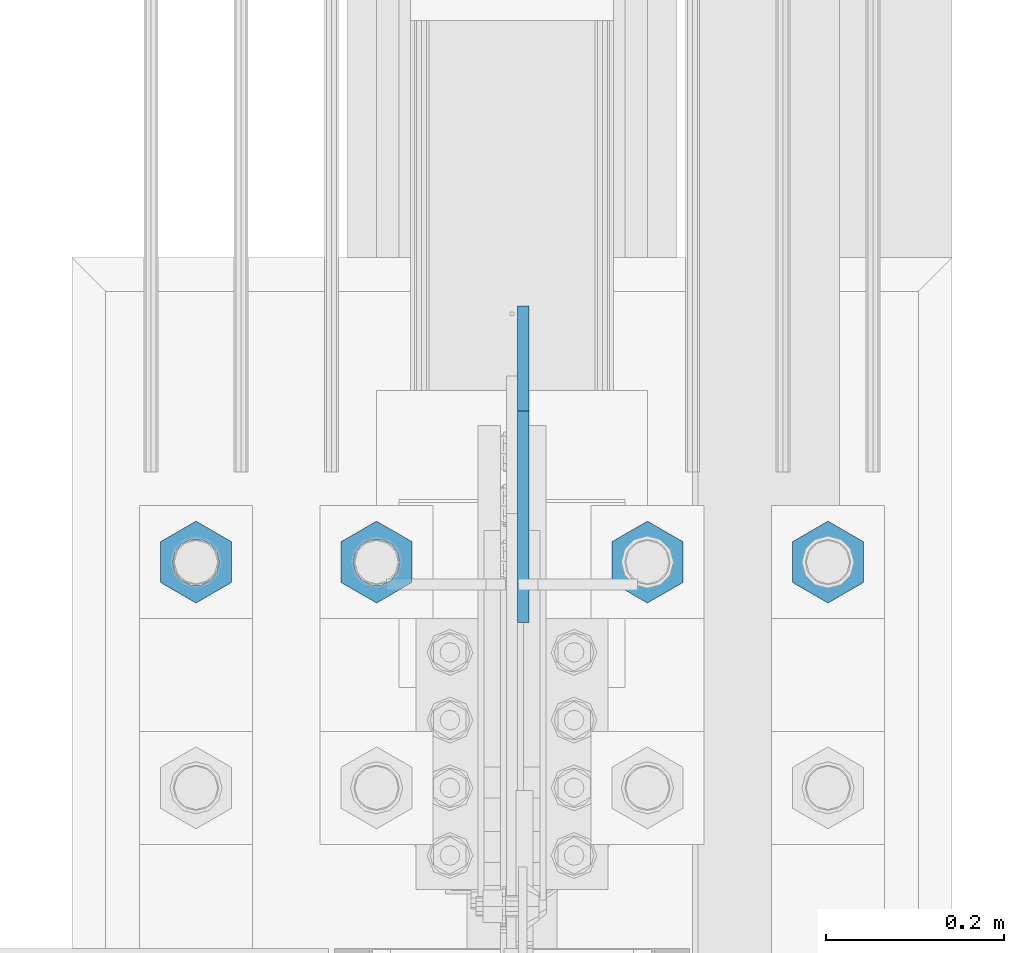
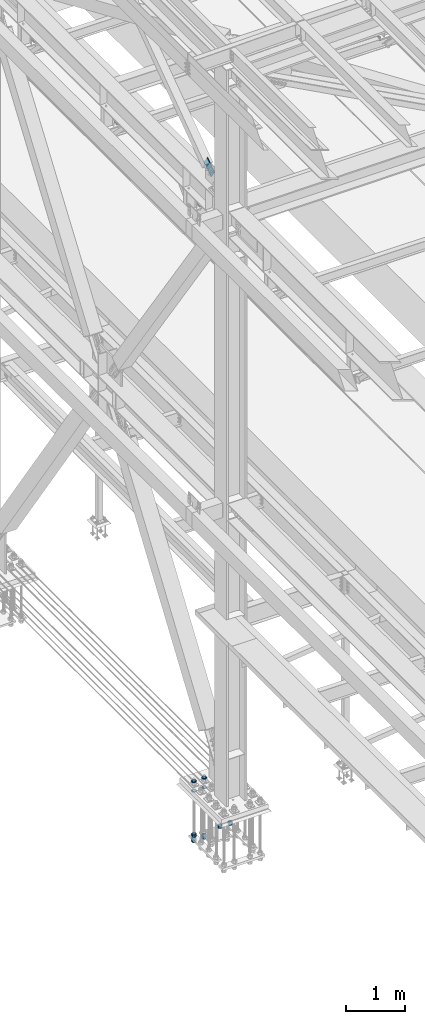
# One storey, part 2370 of 3843: 11 beams, 1 member, 2 elements without a shape of their own.
"""IFC2X3 building model written with IfcOpenShell, lengths in millimetres."""

from ifc_helpers import new_model, si_unit, frame, origin_with_axes, place, context, subcontext, project, spatial, faceted_brep, material, type_object, element, aggregate, save


model = new_model("IFC2X3")

# Units and contexts
model_context = context("Model", 3, precision=1e-05, world=origin_with_axes())
body_context = subcontext(model_context, "Body", "Model", "MODEL_VIEW")
ifc_project = project(units=[si_unit("LENGTHUNIT", "METRE", prefix="MILLI"), si_unit("AREAUNIT", "SQUARE_METRE"), si_unit("VOLUMEUNIT", "CUBIC_METRE"), si_unit("MASSUNIT", "GRAM", prefix="KILO"), si_unit("TIMEUNIT", "SECOND"), si_unit("PLANEANGLEUNIT", "RADIAN"), si_unit("SOLIDANGLEUNIT", "STERADIAN"), si_unit("THERMODYNAMICTEMPERATUREUNIT", "DEGREE_CELSIUS"), si_unit("LUMINOUSINTENSITYUNIT", "LUMEN")], contexts=[model_context])

# Site, building, storey
site_placement = place(None, origin_with_axes())
site = spatial("IfcSite", under=ifc_project, at=site_placement, CompositionType="ELEMENT")
building_placement = place(site_placement, origin_with_axes())
building = spatial("IfcBuilding", under=site, at=building_placement, Name="Undefined", CompositionType="ELEMENT")
storey_placement = place(building_placement, origin_with_axes())
storey = spatial("IfcBuildingStorey", under=building, at=storey_placement, Name="Undefined", CompositionType="ELEMENT", Elevation=0.0)

# Assembly, beams
assembly_1_placement = place(storey_placement, origin_with_axes())
assembly_1 = element("IfcElementAssembly", 1, at=assembly_1_placement, inside=storey, Name="TEMPLATE", AssemblyPlace="NOTDEFINED", PredefinedType="RIGID_FRAME")
ifc_material = material(Name="STEEL/A572-50")
beam_type_1 = type_object("IfcBeamType", Name="2_HALF_NUT", PredefinedType="NOTDEFINED")
beam_1_placement = place(assembly_1_placement, frame((36423.6, 67906.9, 30060.9), z_axis=(1.0, 0.0, 0.0), x_axis=(0.0, 0.0, -1.0)))
beam_1 = element("IfcBeam", 2, at=beam_1_placement, type_object=beam_type_1, material=ifc_material, Name="NUT", ObjectType="2_HALF_NUT", context=body_context, shape_type="Brep", body=[
    faceted_brep([(0.0, -46.0369987487793, 0.0), (0.0, -23.0184993743896, -39.869213104248), (25.4000000000015, -23.0184993743896, -39.869213104248), (25.4000000000015, -46.0369987487793, 0.0), (0.0, 23.0184993743896, -39.869213104248), (25.4000000000015, 23.0184993743896, -39.869213104248), (0.0, 46.0369987487793, 0.0), (25.4000000000015, 46.0369987487793, 0.0), (0.0, 23.0184993743896, 39.869213104248), (25.4000000000015, 23.0184993743896, 39.869213104248), (0.0, -23.0184993743896, 39.869213104248), (25.4000000000015, -23.0184993743896, 39.869213104248), (0.0, 0.0, 26.1940002441406), (0.0, 11.3650617044477, 23.5999013092805), (25.4000000000015, 11.3650617044477, 23.5999013092805), (25.4000000000015, 0.0, 26.1940002441406), (0.0, 20.4791109456419, 16.3316083006721), (25.4000000000015, 20.4791109456419, 16.3316083006721), (0.0, 25.5370200498292, 5.82867859874386), (25.4000000000015, 25.5370200498292, 5.82867859874386), (0.0, 25.5370200498292, -5.82867859874386), (25.4000000000015, 25.5370200498292, -5.82867859874386), (0.0, 20.4791109456419, -16.3316083006721), (25.4000000000015, 20.4791109456419, -16.3316083006721), (0.0, 11.3650617044477, -23.5999013092805), (25.4000000000015, 11.3650617044477, -23.5999013092805), (0.0, 0.0, -26.1940002441406), (25.4000000000015, 0.0, -26.1940002441406), (0.0, -11.3650617044477, -23.5999013092805), (25.4000000000015, -11.3650617044477, -23.5999013092805), (0.0, -20.4791109456419, -16.3316083006721), (25.4000000000015, -20.4791109456419, -16.3316083006721), (0.0, -25.5370200498292, -5.82867859874386), (25.4000000000015, -25.5370200498292, -5.82867859874386), (0.0, -25.5370200498292, 5.82867859874386), (25.4000000000015, -25.5370200498292, 5.82867859874386), (0.0, -20.4791109456419, 16.3316083006721), (25.4000000000015, -20.4791109456419, 16.3316083006721), (0.0, -11.3650617044477, 23.5999013092805), (25.4000000000015, -11.3650617044477, 23.5999013092805)], [[[0, 1, 2, 3]], [[1, 4, 5, 2]], [[4, 6, 7, 5]], [[6, 8, 9, 7]], [[8, 10, 11, 9]], [[10, 0, 3, 11]], [[12, 13, 14, 15]], [[13, 16, 17, 14]], [[16, 18, 19, 17]], [[18, 20, 21, 19]], [[20, 22, 23, 21]], [[22, 24, 25, 23]], [[24, 26, 27, 25]], [[26, 28, 29, 27]], [[28, 30, 31, 29]], [[30, 32, 33, 31]], [[32, 34, 35, 33]], [[34, 36, 37, 35]], [[36, 38, 39, 37]], [[38, 12, 15, 39]], [[5, 7, 9, 11, 3, 2], [17, 19, 21, 23, 25, 27, 29, 31, 33, 35, 37, 39, 15, 14]], [[10, 8, 6, 4, 1, 0], [38, 36, 34, 32, 30, 28, 26, 24, 22, 20, 18, 16, 13, 12]]]),
])
beam_2_placement = place(assembly_1_placement, frame((36220.4, 67906.9, 30060.9), z_axis=(1.0, 0.0, 0.0), x_axis=(0.0, 0.0, -1.0)))
beam_2 = element("IfcBeam", 3, at=beam_2_placement, type_object=beam_type_1, material=ifc_material, Name="NUT", ObjectType="2_HALF_NUT", context=body_context, shape_type="Brep", body=[
    faceted_brep([(0.0, -46.0369987487793, 0.0), (0.0, -23.0184993743896, -39.869213104248), (25.4000000000015, -23.0184993743896, -39.869213104248), (25.4000000000015, -46.0369987487793, 0.0), (0.0, 23.0184993743896, -39.869213104248), (25.4000000000015, 23.0184993743896, -39.869213104248), (0.0, 46.0369987487793, 0.0), (25.4000000000015, 46.0369987487793, 0.0), (0.0, 23.0184993743896, 39.869213104248), (25.4000000000015, 23.0184993743896, 39.869213104248), (0.0, -23.0184993743896, 39.869213104248), (25.4000000000015, -23.0184993743896, 39.869213104248), (0.0, 0.0, 26.1940002441406), (0.0, 11.3650617044477, 23.5999013092805), (25.4000000000015, 11.3650617044477, 23.5999013092805), (25.4000000000015, 0.0, 26.1940002441406), (0.0, 20.4791109456419, 16.3316083006721), (25.4000000000015, 20.4791109456419, 16.3316083006721), (0.0, 25.5370200498292, 5.82867859874386), (25.4000000000015, 25.5370200498292, 5.82867859874386), (0.0, 25.5370200498292, -5.82867859874386), (25.4000000000015, 25.5370200498292, -5.82867859874386), (0.0, 20.4791109456419, -16.3316083006721), (25.4000000000015, 20.4791109456419, -16.3316083006721), (0.0, 11.3650617044477, -23.5999013092805), (25.4000000000015, 11.3650617044477, -23.5999013092805), (0.0, 0.0, -26.1940002441406), (25.4000000000015, 0.0, -26.1940002441406), (0.0, -11.3650617044477, -23.5999013092805), (25.4000000000015, -11.3650617044477, -23.5999013092805), (0.0, -20.4791109456419, -16.3316083006721), (25.4000000000015, -20.4791109456419, -16.3316083006721), (0.0, -25.5370200498292, -5.82867859874386), (25.4000000000015, -25.5370200498292, -5.82867859874386), (0.0, -25.5370200498292, 5.82867859874386), (25.4000000000015, -25.5370200498292, 5.82867859874386), (0.0, -20.4791109456419, 16.3316083006721), (25.4000000000015, -20.4791109456419, 16.3316083006721), (0.0, -11.3650617044477, 23.5999013092805), (25.4000000000015, -11.3650617044477, 23.5999013092805)], [[[0, 1, 2, 3]], [[1, 4, 5, 2]], [[4, 6, 7, 5]], [[6, 8, 9, 7]], [[8, 10, 11, 9]], [[10, 0, 3, 11]], [[12, 13, 14, 15]], [[13, 16, 17, 14]], [[16, 18, 19, 17]], [[18, 20, 21, 19]], [[20, 22, 23, 21]], [[22, 24, 25, 23]], [[24, 26, 27, 25]], [[26, 28, 29, 27]], [[28, 30, 31, 29]], [[30, 32, 33, 31]], [[32, 34, 35, 33]], [[34, 36, 37, 35]], [[36, 38, 39, 37]], [[38, 12, 15, 39]], [[5, 7, 9, 11, 3, 2], [17, 19, 21, 23, 25, 27, 29, 31, 33, 35, 37, 39, 15, 14]], [[10, 8, 6, 4, 1, 0], [38, 36, 34, 32, 30, 28, 26, 24, 22, 20, 18, 16, 13, 12]]]),
])
beam_3_placement = place(assembly_1_placement, frame((36423.6, 67906.9, 30257.75), z_axis=(-1.0, 0.0, 0.0), x_axis=(0.0, 0.0, -1.0)))
beam_3 = element("IfcBeam", 4, at=beam_3_placement, type_object=beam_type_1, material=ifc_material, Name="NUT", ObjectType="2_HALF_NUT", context=body_context, shape_type="Brep", body=[
    faceted_brep([(0.0, -46.0369987487793, 0.0), (0.0, -23.0184993743896, -39.869213104248), (25.4000000000015, -23.0184993743896, -39.869213104248), (25.4000000000015, -46.0369987487793, 0.0), (0.0, 23.0184993743896, -39.869213104248), (25.4000000000015, 23.0184993743896, -39.869213104248), (0.0, 46.0369987487793, 0.0), (25.4000000000015, 46.0369987487793, 0.0), (0.0, 23.0184993743896, 39.869213104248), (25.4000000000015, 23.0184993743896, 39.869213104248), (0.0, -23.0184993743896, 39.869213104248), (25.4000000000015, -23.0184993743896, 39.869213104248), (0.0, 0.0, 26.1940002441406), (0.0, 11.3650617044477, 23.5999013092805), (25.4000000000015, 11.3650617044477, 23.5999013092805), (25.4000000000015, 0.0, 26.1940002441406), (0.0, 20.4791109456419, 16.3316083006721), (25.4000000000015, 20.4791109456419, 16.3316083006721), (0.0, 25.5370200498292, 5.82867859874386), (25.4000000000015, 25.5370200498292, 5.82867859874386), (0.0, 25.5370200498292, -5.82867859874386), (25.4000000000015, 25.5370200498292, -5.82867859874386), (0.0, 20.4791109456419, -16.3316083006721), (25.4000000000015, 20.4791109456419, -16.3316083006721), (0.0, 11.3650617044477, -23.5999013092805), (25.4000000000015, 11.3650617044477, -23.5999013092805), (0.0, 0.0, -26.1940002441406), (25.4000000000015, 0.0, -26.1940002441406), (0.0, -11.3650617044477, -23.5999013092805), (25.4000000000015, -11.3650617044477, -23.5999013092805), (0.0, -20.4791109456419, -16.3316083006721), (25.4000000000015, -20.4791109456419, -16.3316083006721), (0.0, -25.5370200498292, -5.82867859874386), (25.4000000000015, -25.5370200498292, -5.82867859874386), (0.0, -25.5370200498292, 5.82867859874386), (25.4000000000015, -25.5370200498292, 5.82867859874386), (0.0, -20.4791109456419, 16.3316083006721), (25.4000000000015, -20.4791109456419, 16.3316083006721), (0.0, -11.3650617044477, 23.5999013092805), (25.4000000000015, -11.3650617044477, 23.5999013092805)], [[[0, 1, 2, 3]], [[1, 4, 5, 2]], [[4, 6, 7, 5]], [[6, 8, 9, 7]], [[8, 10, 11, 9]], [[10, 0, 3, 11]], [[12, 13, 14, 15]], [[13, 16, 17, 14]], [[16, 18, 19, 17]], [[18, 20, 21, 19]], [[20, 22, 23, 21]], [[22, 24, 25, 23]], [[24, 26, 27, 25]], [[26, 28, 29, 27]], [[28, 30, 31, 29]], [[30, 32, 33, 31]], [[32, 34, 35, 33]], [[34, 36, 37, 35]], [[36, 38, 39, 37]], [[38, 12, 15, 39]], [[5, 7, 9, 11, 3, 2], [17, 19, 21, 23, 25, 27, 29, 31, 33, 35, 37, 39, 15, 14]], [[10, 8, 6, 4, 1, 0], [38, 36, 34, 32, 30, 28, 26, 24, 22, 20, 18, 16, 13, 12]]]),
])
beam_4_placement = place(assembly_1_placement, frame((36220.4, 67906.9, 30257.75), z_axis=(-1.0, 0.0, 0.0), x_axis=(0.0, 0.0, -1.0)))
beam_4 = element("IfcBeam", 5, at=beam_4_placement, type_object=beam_type_1, material=ifc_material, Name="NUT", ObjectType="2_HALF_NUT", context=body_context, shape_type="Brep", body=[
    faceted_brep([(0.0, -46.0369987487793, 0.0), (0.0, -23.0184993743896, -39.869213104248), (25.4000000000015, -23.0184993743896, -39.869213104248), (25.4000000000015, -46.0369987487793, 0.0), (0.0, 23.0184993743896, -39.869213104248), (25.4000000000015, 23.0184993743896, -39.869213104248), (0.0, 46.0369987487793, 0.0), (25.4000000000015, 46.0369987487793, 0.0), (0.0, 23.0184993743896, 39.869213104248), (25.4000000000015, 23.0184993743896, 39.869213104248), (0.0, -23.0184993743896, 39.869213104248), (25.4000000000015, -23.0184993743896, 39.869213104248), (0.0, 0.0, 26.1940002441406), (0.0, 11.3650617044477, 23.5999013092805), (25.4000000000015, 11.3650617044477, 23.5999013092805), (25.4000000000015, 0.0, 26.1940002441406), (0.0, 20.4791109456419, 16.3316083006721), (25.4000000000015, 20.4791109456419, 16.3316083006721), (0.0, 25.5370200498292, 5.82867859874386), (25.4000000000015, 25.5370200498292, 5.82867859874386), (0.0, 25.5370200498292, -5.82867859874386), (25.4000000000015, 25.5370200498292, -5.82867859874386), (0.0, 20.4791109456419, -16.3316083006721), (25.4000000000015, 20.4791109456419, -16.3316083006721), (0.0, 11.3650617044477, -23.5999013092805), (25.4000000000015, 11.3650617044477, -23.5999013092805), (0.0, 0.0, -26.1940002441406), (25.4000000000015, 0.0, -26.1940002441406), (0.0, -11.3650617044477, -23.5999013092805), (25.4000000000015, -11.3650617044477, -23.5999013092805), (0.0, -20.4791109456419, -16.3316083006721), (25.4000000000015, -20.4791109456419, -16.3316083006721), (0.0, -25.5370200498292, -5.82867859874386), (25.4000000000015, -25.5370200498292, -5.82867859874386), (0.0, -25.5370200498292, 5.82867859874386), (25.4000000000015, -25.5370200498292, 5.82867859874386), (0.0, -20.4791109456419, 16.3316083006721), (25.4000000000015, -20.4791109456419, 16.3316083006721), (0.0, -11.3650617044477, 23.5999013092805), (25.4000000000015, -11.3650617044477, 23.5999013092805)], [[[0, 1, 2, 3]], [[1, 4, 5, 2]], [[4, 6, 7, 5]], [[6, 8, 9, 7]], [[8, 10, 11, 9]], [[10, 0, 3, 11]], [[12, 13, 14, 15]], [[13, 16, 17, 14]], [[16, 18, 19, 17]], [[18, 20, 21, 19]], [[20, 22, 23, 21]], [[22, 24, 25, 23]], [[24, 26, 27, 25]], [[26, 28, 29, 27]], [[28, 30, 31, 29]], [[30, 32, 33, 31]], [[32, 34, 35, 33]], [[34, 36, 37, 35]], [[36, 38, 39, 37]], [[38, 12, 15, 39]], [[5, 7, 9, 11, 3, 2], [17, 19, 21, 23, 25, 27, 29, 31, 33, 35, 37, 39, 15, 14]], [[10, 8, 6, 4, 1, 0], [38, 36, 34, 32, 30, 28, 26, 24, 22, 20, 18, 16, 13, 12]]]),
])
beam_5_placement = place(assembly_1_placement, frame((36423.6, 67906.9, 29070.3), z_axis=(-1.0, 0.0, 0.0), x_axis=(0.0, 0.0, -1.0)))
beam_5 = element("IfcBeam", 6, at=beam_5_placement, type_object=beam_type_1, material=ifc_material, Name="NUT", ObjectType="2_HALF_NUT", context=body_context, shape_type="Brep", body=[
    faceted_brep([(0.0, -46.0369987487793, 0.0), (0.0, -23.0184993743896, -39.869213104248), (25.4000000000015, -23.0184993743896, -39.869213104248), (25.4000000000015, -46.0369987487793, 0.0), (0.0, 23.0184993743896, -39.869213104248), (25.4000000000015, 23.0184993743896, -39.869213104248), (0.0, 46.0369987487793, 0.0), (25.4000000000015, 46.0369987487793, 0.0), (0.0, 23.0184993743896, 39.869213104248), (25.4000000000015, 23.0184993743896, 39.869213104248), (0.0, -23.0184993743896, 39.869213104248), (25.4000000000015, -23.0184993743896, 39.869213104248), (0.0, 0.0, 26.1940002441406), (0.0, 11.3650617044477, 23.5999013092805), (25.4000000000015, 11.3650617044477, 23.5999013092805), (25.4000000000015, 0.0, 26.1940002441406), (0.0, 20.4791109456419, 16.3316083006721), (25.4000000000015, 20.4791109456419, 16.3316083006721), (0.0, 25.5370200498292, 5.82867859874386), (25.4000000000015, 25.5370200498292, 5.82867859874386), (0.0, 25.5370200498292, -5.82867859874386), (25.4000000000015, 25.5370200498292, -5.82867859874386), (0.0, 20.4791109456419, -16.3316083006721), (25.4000000000015, 20.4791109456419, -16.3316083006721), (0.0, 11.3650617044477, -23.5999013092805), (25.4000000000015, 11.3650617044477, -23.5999013092805), (0.0, 0.0, -26.1940002441406), (25.4000000000015, 0.0, -26.1940002441406), (0.0, -11.3650617044477, -23.5999013092805), (25.4000000000015, -11.3650617044477, -23.5999013092805), (0.0, -20.4791109456419, -16.3316083006721), (25.4000000000015, -20.4791109456419, -16.3316083006721), (0.0, -25.5370200498292, -5.82867859874386), (25.4000000000015, -25.5370200498292, -5.82867859874386), (0.0, -25.5370200498292, 5.82867859874386), (25.4000000000015, -25.5370200498292, 5.82867859874386), (0.0, -20.4791109456419, 16.3316083006721), (25.4000000000015, -20.4791109456419, 16.3316083006721), (0.0, -11.3650617044477, 23.5999013092805), (25.4000000000015, -11.3650617044477, 23.5999013092805)], [[[0, 1, 2, 3]], [[1, 4, 5, 2]], [[4, 6, 7, 5]], [[6, 8, 9, 7]], [[8, 10, 11, 9]], [[10, 0, 3, 11]], [[12, 13, 14, 15]], [[13, 16, 17, 14]], [[16, 18, 19, 17]], [[18, 20, 21, 19]], [[20, 22, 23, 21]], [[22, 24, 25, 23]], [[24, 26, 27, 25]], [[26, 28, 29, 27]], [[28, 30, 31, 29]], [[30, 32, 33, 31]], [[32, 34, 35, 33]], [[34, 36, 37, 35]], [[36, 38, 39, 37]], [[38, 12, 15, 39]], [[5, 7, 9, 11, 3, 2], [17, 19, 21, 23, 25, 27, 29, 31, 33, 35, 37, 39, 15, 14]], [[10, 8, 6, 4, 1, 0], [38, 36, 34, 32, 30, 28, 26, 24, 22, 20, 18, 16, 13, 12]]]),
])
beam_6_placement = place(assembly_1_placement, frame((36220.4, 67906.9, 29070.3), z_axis=(-1.0, 0.0, 0.0), x_axis=(0.0, 0.0, -1.0)))
beam_6 = element("IfcBeam", 7, at=beam_6_placement, type_object=beam_type_1, material=ifc_material, Name="NUT", ObjectType="2_HALF_NUT", context=body_context, shape_type="Brep", body=[
    faceted_brep([(0.0, -46.0369987487793, 0.0), (0.0, -23.0184993743896, -39.869213104248), (25.4000000000015, -23.0184993743896, -39.869213104248), (25.4000000000015, -46.0369987487793, 0.0), (0.0, 23.0184993743896, -39.869213104248), (25.4000000000015, 23.0184993743896, -39.869213104248), (0.0, 46.0369987487793, 0.0), (25.4000000000015, 46.0369987487793, 0.0), (0.0, 23.0184993743896, 39.869213104248), (25.4000000000015, 23.0184993743896, 39.869213104248), (0.0, -23.0184993743896, 39.869213104248), (25.4000000000015, -23.0184993743896, 39.869213104248), (0.0, 0.0, 26.1940002441406), (0.0, 11.3650617044477, 23.5999013092805), (25.4000000000015, 11.3650617044477, 23.5999013092805), (25.4000000000015, 0.0, 26.1940002441406), (0.0, 20.4791109456419, 16.3316083006721), (25.4000000000015, 20.4791109456419, 16.3316083006721), (0.0, 25.5370200498292, 5.82867859874386), (25.4000000000015, 25.5370200498292, 5.82867859874386), (0.0, 25.5370200498292, -5.82867859874386), (25.4000000000015, 25.5370200498292, -5.82867859874386), (0.0, 20.4791109456419, -16.3316083006721), (25.4000000000015, 20.4791109456419, -16.3316083006721), (0.0, 11.3650617044477, -23.5999013092805), (25.4000000000015, 11.3650617044477, -23.5999013092805), (0.0, 0.0, -26.1940002441406), (25.4000000000015, 0.0, -26.1940002441406), (0.0, -11.3650617044477, -23.5999013092805), (25.4000000000015, -11.3650617044477, -23.5999013092805), (0.0, -20.4791109456419, -16.3316083006721), (25.4000000000015, -20.4791109456419, -16.3316083006721), (0.0, -25.5370200498292, -5.82867859874386), (25.4000000000015, -25.5370200498292, -5.82867859874386), (0.0, -25.5370200498292, 5.82867859874386), (25.4000000000015, -25.5370200498292, 5.82867859874386), (0.0, -20.4791109456419, 16.3316083006721), (25.4000000000015, -20.4791109456419, 16.3316083006721), (0.0, -11.3650617044477, 23.5999013092805), (25.4000000000015, -11.3650617044477, 23.5999013092805)], [[[0, 1, 2, 3]], [[1, 4, 5, 2]], [[4, 6, 7, 5]], [[6, 8, 9, 7]], [[8, 10, 11, 9]], [[10, 0, 3, 11]], [[12, 13, 14, 15]], [[13, 16, 17, 14]], [[16, 18, 19, 17]], [[18, 20, 21, 19]], [[20, 22, 23, 21]], [[22, 24, 25, 23]], [[24, 26, 27, 25]], [[26, 28, 29, 27]], [[28, 30, 31, 29]], [[30, 32, 33, 31]], [[32, 34, 35, 33]], [[34, 36, 37, 35]], [[36, 38, 39, 37]], [[38, 12, 15, 39]], [[5, 7, 9, 11, 3, 2], [17, 19, 21, 23, 25, 27, 29, 31, 33, 35, 37, 39, 15, 14]], [[10, 8, 6, 4, 1, 0], [38, 36, 34, 32, 30, 28, 26, 24, 22, 20, 18, 16, 13, 12]]]),
])
beam_type_2 = type_object("IfcBeamType", Name="2_HEAVY_HEX_NUT", PredefinedType="NOTDEFINED")
beam_7_placement = place(assembly_1_placement, frame((36728.4, 67906.9, 29159.2), z_axis=(-1.0, 0.0, 0.0), x_axis=(0.0, 0.0, -1.0)))
beam_7 = element("IfcBeam", 8, at=beam_7_placement, type_object=beam_type_2, material=ifc_material, Name="NUT", ObjectType="2_HEAVY_HEX_NUT", context=body_context, shape_type="Brep", body=[
    faceted_brep([(0.0, -46.0369987487793, 0.0), (0.0, -23.0184993743896, -39.869213104248), (50.7999999999993, -23.0184993743896, -39.869213104248), (50.7999999999993, -46.0369987487793, 0.0), (0.0, 23.0184993743896, -39.869213104248), (50.7999999999993, 23.0184993743896, -39.869213104248), (0.0, 46.0369987487793, 0.0), (50.7999999999993, 46.0369987487793, 0.0), (0.0, 23.0184993743896, 39.869213104248), (50.7999999999993, 23.0184993743896, 39.869213104248), (0.0, -23.0184993743896, 39.869213104248), (50.7999999999993, -23.0184993743896, 39.869213104248), (0.0, 0.0, 26.1940002441406), (0.0, 11.3650617044477, 23.5999013092805), (50.7999999999993, 11.3650617044477, 23.5999013092805), (50.7999999999993, 0.0, 26.1940002441406), (0.0, 20.4791109456419, 16.3316083006721), (50.7999999999993, 20.4791109456419, 16.3316083006721), (0.0, 25.5370200498292, 5.82867859874386), (50.7999999999993, 25.5370200498292, 5.82867859874386), (0.0, 25.5370200498292, -5.82867859874386), (50.7999999999993, 25.5370200498292, -5.82867859874386), (0.0, 20.4791109456419, -16.3316083006721), (50.7999999999993, 20.4791109456419, -16.3316083006721), (0.0, 11.3650617044477, -23.5999013092805), (50.7999999999993, 11.3650617044477, -23.5999013092805), (0.0, 0.0, -26.1940002441406), (50.7999999999993, 0.0, -26.1940002441406), (0.0, -11.3650617044477, -23.5999013092805), (50.7999999999993, -11.3650617044477, -23.5999013092805), (0.0, -20.4791109456419, -16.3316083006721), (50.7999999999993, -20.4791109456419, -16.3316083006721), (0.0, -25.5370200498292, -5.82867859874386), (50.7999999999993, -25.5370200498292, -5.82867859874386), (0.0, -25.5370200498292, 5.82867859874386), (50.7999999999993, -25.5370200498292, 5.82867859874386), (0.0, -20.4791109456419, 16.3316083006721), (50.7999999999993, -20.4791109456419, 16.3316083006721), (0.0, -11.3650617044477, 23.5999013092805), (50.7999999999993, -11.3650617044477, 23.5999013092805)], [[[0, 1, 2, 3]], [[1, 4, 5, 2]], [[4, 6, 7, 5]], [[6, 8, 9, 7]], [[8, 10, 11, 9]], [[10, 0, 3, 11]], [[12, 13, 14, 15]], [[13, 16, 17, 14]], [[16, 18, 19, 17]], [[18, 20, 21, 19]], [[20, 22, 23, 21]], [[22, 24, 25, 23]], [[24, 26, 27, 25]], [[26, 28, 29, 27]], [[28, 30, 31, 29]], [[30, 32, 33, 31]], [[32, 34, 35, 33]], [[34, 36, 37, 35]], [[36, 38, 39, 37]], [[38, 12, 15, 39]], [[5, 7, 9, 11, 3, 2], [17, 19, 21, 23, 25, 27, 29, 31, 33, 35, 37, 39, 15, 14]], [[10, 8, 6, 4, 1, 0], [38, 36, 34, 32, 30, 28, 26, 24, 22, 20, 18, 16, 13, 12]]]),
])
beam_8_placement = place(assembly_1_placement, frame((36220.4, 67906.9, 29159.2), z_axis=(-1.0, 0.0, 0.0), x_axis=(0.0, 0.0, -1.0)))
beam_8 = element("IfcBeam", 9, at=beam_8_placement, type_object=beam_type_2, material=ifc_material, Name="NUT", ObjectType="2_HEAVY_HEX_NUT", context=body_context, shape_type="Brep", body=[
    faceted_brep([(0.0, -46.0369987487793, 0.0), (0.0, -23.0184993743896, -39.869213104248), (50.7999999999993, -23.0184993743896, -39.869213104248), (50.7999999999993, -46.0369987487793, 0.0), (0.0, 23.0184993743896, -39.869213104248), (50.7999999999993, 23.0184993743896, -39.869213104248), (0.0, 46.0369987487793, 0.0), (50.7999999999993, 46.0369987487793, 0.0), (0.0, 23.0184993743896, 39.869213104248), (50.7999999999993, 23.0184993743896, 39.869213104248), (0.0, -23.0184993743896, 39.869213104248), (50.7999999999993, -23.0184993743896, 39.869213104248), (0.0, 0.0, 26.1940002441406), (0.0, 11.3650617044477, 23.5999013092805), (50.7999999999993, 11.3650617044477, 23.5999013092805), (50.7999999999993, 0.0, 26.1940002441406), (0.0, 20.4791109456419, 16.3316083006721), (50.7999999999993, 20.4791109456419, 16.3316083006721), (0.0, 25.5370200498292, 5.82867859874386), (50.7999999999993, 25.5370200498292, 5.82867859874386), (0.0, 25.5370200498292, -5.82867859874386), (50.7999999999993, 25.5370200498292, -5.82867859874386), (0.0, 20.4791109456419, -16.3316083006721), (50.7999999999993, 20.4791109456419, -16.3316083006721), (0.0, 11.3650617044477, -23.5999013092805), (50.7999999999993, 11.3650617044477, -23.5999013092805), (0.0, 0.0, -26.1940002441406), (50.7999999999993, 0.0, -26.1940002441406), (0.0, -11.3650617044477, -23.5999013092805), (50.7999999999993, -11.3650617044477, -23.5999013092805), (0.0, -20.4791109456419, -16.3316083006721), (50.7999999999993, -20.4791109456419, -16.3316083006721), (0.0, -25.5370200498292, -5.82867859874386), (50.7999999999993, -25.5370200498292, -5.82867859874386), (0.0, -25.5370200498292, 5.82867859874386), (50.7999999999993, -25.5370200498292, 5.82867859874386), (0.0, -20.4791109456419, 16.3316083006721), (50.7999999999993, -20.4791109456419, 16.3316083006721), (0.0, -11.3650617044477, 23.5999013092805), (50.7999999999993, -11.3650617044477, 23.5999013092805)], [[[0, 1, 2, 3]], [[1, 4, 5, 2]], [[4, 6, 7, 5]], [[6, 8, 9, 7]], [[8, 10, 11, 9]], [[10, 0, 3, 11]], [[12, 13, 14, 15]], [[13, 16, 17, 14]], [[16, 18, 19, 17]], [[18, 20, 21, 19]], [[20, 22, 23, 21]], [[22, 24, 25, 23]], [[24, 26, 27, 25]], [[26, 28, 29, 27]], [[28, 30, 31, 29]], [[30, 32, 33, 31]], [[32, 34, 35, 33]], [[34, 36, 37, 35]], [[36, 38, 39, 37]], [[38, 12, 15, 39]], [[5, 7, 9, 11, 3, 2], [17, 19, 21, 23, 25, 27, 29, 31, 33, 35, 37, 39, 15, 14]], [[10, 8, 6, 4, 1, 0], [38, 36, 34, 32, 30, 28, 26, 24, 22, 20, 18, 16, 13, 12]]]),
])
beam_9_placement = place(assembly_1_placement, frame((36931.6, 67906.9, 29159.2), z_axis=(-1.0, 0.0, 0.0), x_axis=(0.0, 0.0, -1.0)))
beam_9 = element("IfcBeam", 10, at=beam_9_placement, type_object=beam_type_2, material=ifc_material, Name="NUT", ObjectType="2_HEAVY_HEX_NUT", context=body_context, shape_type="Brep", body=[
    faceted_brep([(0.0, -46.0369987487793, 0.0), (0.0, -23.0184993743896, -39.869213104248), (50.7999999999993, -23.0184993743896, -39.869213104248), (50.7999999999993, -46.0369987487793, 0.0), (0.0, 23.0184993743896, -39.869213104248), (50.7999999999993, 23.0184993743896, -39.869213104248), (0.0, 46.0369987487793, 0.0), (50.7999999999993, 46.0369987487793, 0.0), (0.0, 23.0184993743896, 39.869213104248), (50.7999999999993, 23.0184993743896, 39.869213104248), (0.0, -23.0184993743896, 39.869213104248), (50.7999999999993, -23.0184993743896, 39.869213104248), (0.0, 0.0, 26.1940002441406), (0.0, 11.3650617044477, 23.5999013092805), (50.7999999999993, 11.3650617044477, 23.5999013092805), (50.7999999999993, 0.0, 26.1940002441406), (0.0, 20.4791109456419, 16.3316083006721), (50.7999999999993, 20.4791109456419, 16.3316083006721), (0.0, 25.5370200498292, 5.82867859874386), (50.7999999999993, 25.5370200498292, 5.82867859874386), (0.0, 25.5370200498292, -5.82867859874386), (50.7999999999993, 25.5370200498292, -5.82867859874386), (0.0, 20.4791109456419, -16.3316083006721), (50.7999999999993, 20.4791109456419, -16.3316083006721), (0.0, 11.3650617044477, -23.5999013092805), (50.7999999999993, 11.3650617044477, -23.5999013092805), (0.0, 0.0, -26.1940002441406), (50.7999999999993, 0.0, -26.1940002441406), (0.0, -11.3650617044477, -23.5999013092805), (50.7999999999993, -11.3650617044477, -23.5999013092805), (0.0, -20.4791109456419, -16.3316083006721), (50.7999999999993, -20.4791109456419, -16.3316083006721), (0.0, -25.5370200498292, -5.82867859874386), (50.7999999999993, -25.5370200498292, -5.82867859874386), (0.0, -25.5370200498292, 5.82867859874386), (50.7999999999993, -25.5370200498292, 5.82867859874386), (0.0, -20.4791109456419, 16.3316083006721), (50.7999999999993, -20.4791109456419, 16.3316083006721), (0.0, -11.3650617044477, 23.5999013092805), (50.7999999999993, -11.3650617044477, 23.5999013092805)], [[[0, 1, 2, 3]], [[1, 4, 5, 2]], [[4, 6, 7, 5]], [[6, 8, 9, 7]], [[8, 10, 11, 9]], [[10, 0, 3, 11]], [[12, 13, 14, 15]], [[13, 16, 17, 14]], [[16, 18, 19, 17]], [[18, 20, 21, 19]], [[20, 22, 23, 21]], [[22, 24, 25, 23]], [[24, 26, 27, 25]], [[26, 28, 29, 27]], [[28, 30, 31, 29]], [[30, 32, 33, 31]], [[32, 34, 35, 33]], [[34, 36, 37, 35]], [[36, 38, 39, 37]], [[38, 12, 15, 39]], [[5, 7, 9, 11, 3, 2], [17, 19, 21, 23, 25, 27, 29, 31, 33, 35, 37, 39, 15, 14]], [[10, 8, 6, 4, 1, 0], [38, 36, 34, 32, 30, 28, 26, 24, 22, 20, 18, 16, 13, 12]]]),
])
beam_10_placement = place(assembly_1_placement, frame((36423.6, 67906.9, 29044.9), z_axis=(-1.0, 0.0, 0.0), x_axis=(0.0, 0.0, -1.0)))
beam_10 = element("IfcBeam", 11, at=beam_10_placement, type_object=beam_type_2, material=ifc_material, Name="NUT", ObjectType="2_HEAVY_HEX_NUT", context=body_context, shape_type="Brep", body=[
    faceted_brep([(0.0, -46.0369987487793, 0.0), (0.0, -23.0184993743896, -39.869213104248), (50.7999999999993, -23.0184993743896, -39.869213104248), (50.7999999999993, -46.0369987487793, 0.0), (0.0, 23.0184993743896, -39.869213104248), (50.7999999999993, 23.0184993743896, -39.869213104248), (0.0, 46.0369987487793, 0.0), (50.7999999999993, 46.0369987487793, 0.0), (0.0, 23.0184993743896, 39.869213104248), (50.7999999999993, 23.0184993743896, 39.869213104248), (0.0, -23.0184993743896, 39.869213104248), (50.7999999999993, -23.0184993743896, 39.869213104248), (0.0, 0.0, 26.1940002441406), (0.0, 11.3650617044477, 23.5999013092805), (50.7999999999993, 11.3650617044477, 23.5999013092805), (50.7999999999993, 0.0, 26.1940002441406), (0.0, 20.4791109456419, 16.3316083006721), (50.7999999999993, 20.4791109456419, 16.3316083006721), (0.0, 25.5370200498292, 5.82867859874386), (50.7999999999993, 25.5370200498292, 5.82867859874386), (0.0, 25.5370200498292, -5.82867859874386), (50.7999999999993, 25.5370200498292, -5.82867859874386), (0.0, 20.4791109456419, -16.3316083006721), (50.7999999999993, 20.4791109456419, -16.3316083006721), (0.0, 11.3650617044477, -23.5999013092805), (50.7999999999993, 11.3650617044477, -23.5999013092805), (0.0, 0.0, -26.1940002441406), (50.7999999999993, 0.0, -26.1940002441406), (0.0, -11.3650617044477, -23.5999013092805), (50.7999999999993, -11.3650617044477, -23.5999013092805), (0.0, -20.4791109456419, -16.3316083006721), (50.7999999999993, -20.4791109456419, -16.3316083006721), (0.0, -25.5370200498292, -5.82867859874386), (50.7999999999993, -25.5370200498292, -5.82867859874386), (0.0, -25.5370200498292, 5.82867859874386), (50.7999999999993, -25.5370200498292, 5.82867859874386), (0.0, -20.4791109456419, 16.3316083006721), (50.7999999999993, -20.4791109456419, 16.3316083006721), (0.0, -11.3650617044477, 23.5999013092805), (50.7999999999993, -11.3650617044477, 23.5999013092805)], [[[0, 1, 2, 3]], [[1, 4, 5, 2]], [[4, 6, 7, 5]], [[6, 8, 9, 7]], [[8, 10, 11, 9]], [[10, 0, 3, 11]], [[12, 13, 14, 15]], [[13, 16, 17, 14]], [[16, 18, 19, 17]], [[18, 20, 21, 19]], [[20, 22, 23, 21]], [[22, 24, 25, 23]], [[24, 26, 27, 25]], [[26, 28, 29, 27]], [[28, 30, 31, 29]], [[30, 32, 33, 31]], [[32, 34, 35, 33]], [[34, 36, 37, 35]], [[36, 38, 39, 37]], [[38, 12, 15, 39]], [[5, 7, 9, 11, 3, 2], [17, 19, 21, 23, 25, 27, 29, 31, 33, 35, 37, 39, 15, 14]], [[10, 8, 6, 4, 1, 0], [38, 36, 34, 32, 30, 28, 26, 24, 22, 20, 18, 16, 13, 12]]]),
])
beam_11_placement = place(assembly_1_placement, frame((36220.4, 67906.9, 29044.9), z_axis=(-1.0, 0.0, 0.0), x_axis=(0.0, 0.0, -1.0)))
beam_11 = element("IfcBeam", 12, at=beam_11_placement, type_object=beam_type_2, material=ifc_material, Name="NUT", ObjectType="2_HEAVY_HEX_NUT", context=body_context, shape_type="Brep", body=[
    faceted_brep([(0.0, -46.0369987487793, 0.0), (0.0, -23.0184993743896, -39.869213104248), (50.7999999999993, -23.0184993743896, -39.869213104248), (50.7999999999993, -46.0369987487793, 0.0), (0.0, 23.0184993743896, -39.869213104248), (50.7999999999993, 23.0184993743896, -39.869213104248), (0.0, 46.0369987487793, 0.0), (50.7999999999993, 46.0369987487793, 0.0), (0.0, 23.0184993743896, 39.869213104248), (50.7999999999993, 23.0184993743896, 39.869213104248), (0.0, -23.0184993743896, 39.869213104248), (50.7999999999993, -23.0184993743896, 39.869213104248), (0.0, 0.0, 26.1940002441406), (0.0, 11.3650617044477, 23.5999013092805), (50.7999999999993, 11.3650617044477, 23.5999013092805), (50.7999999999993, 0.0, 26.1940002441406), (0.0, 20.4791109456419, 16.3316083006721), (50.7999999999993, 20.4791109456419, 16.3316083006721), (0.0, 25.5370200498292, 5.82867859874386), (50.7999999999993, 25.5370200498292, 5.82867859874386), (0.0, 25.5370200498292, -5.82867859874386), (50.7999999999993, 25.5370200498292, -5.82867859874386), (0.0, 20.4791109456419, -16.3316083006721), (50.7999999999993, 20.4791109456419, -16.3316083006721), (0.0, 11.3650617044477, -23.5999013092805), (50.7999999999993, 11.3650617044477, -23.5999013092805), (0.0, 0.0, -26.1940002441406), (50.7999999999993, 0.0, -26.1940002441406), (0.0, -11.3650617044477, -23.5999013092805), (50.7999999999993, -11.3650617044477, -23.5999013092805), (0.0, -20.4791109456419, -16.3316083006721), (50.7999999999993, -20.4791109456419, -16.3316083006721), (0.0, -25.5370200498292, -5.82867859874386), (50.7999999999993, -25.5370200498292, -5.82867859874386), (0.0, -25.5370200498292, 5.82867859874386), (50.7999999999993, -25.5370200498292, 5.82867859874386), (0.0, -20.4791109456419, 16.3316083006721), (50.7999999999993, -20.4791109456419, 16.3316083006721), (0.0, -11.3650617044477, 23.5999013092805), (50.7999999999993, -11.3650617044477, 23.5999013092805)], [[[0, 1, 2, 3]], [[1, 4, 5, 2]], [[4, 6, 7, 5]], [[6, 8, 9, 7]], [[8, 10, 11, 9]], [[10, 0, 3, 11]], [[12, 13, 14, 15]], [[13, 16, 17, 14]], [[16, 18, 19, 17]], [[18, 20, 21, 19]], [[20, 22, 23, 21]], [[22, 24, 25, 23]], [[24, 26, 27, 25]], [[26, 28, 29, 27]], [[28, 30, 31, 29]], [[30, 32, 33, 31]], [[32, 34, 35, 33]], [[34, 36, 37, 35]], [[36, 38, 39, 37]], [[38, 12, 15, 39]], [[5, 7, 9, 11, 3, 2], [17, 19, 21, 23, 25, 27, 29, 31, 33, 35, 37, 39, 15, 14]], [[10, 8, 6, 4, 1, 0], [38, 36, 34, 32, 30, 28, 26, 24, 22, 20, 18, 16, 13, 12]]]),
])
aggregate(assembly_1, [beam_7, beam_8, beam_9, beam_1, beam_2, beam_3, beam_4, beam_10, beam_5, beam_11, beam_6])

# Assembly, member
assembly_2_placement = place(storey_placement, origin_with_axes())
assembly_2 = element("IfcElementAssembly", 13, at=assembly_2_placement, inside=storey, AssemblyPlace="NOTDEFINED", PredefinedType="RIGID_FRAME")
member_type = type_object("IfcMemberType", PredefinedType="NOTDEFINED")
member_placement = place(assembly_2_placement, frame((36588.7000000077, 67898.0133040465, 42678.5347488085), z_axis=(0.0, 0.58041842979964, -0.814318393718895), x_axis=(0.0, 0.814318393718904, 0.580418429799627)))
member = element("IfcMember", 14, at=member_placement, type_object=member_type, material=ifc_material, Name="PLATE", context=body_context, shape_type="Brep", body=[
    faceted_brep([(1.74622982740402e-10, 6.35000000000582, -101.600000000195), (-1.67347025126219e-10, 6.35000000000582, 101.600000000151), (292.1000000028, 6.35000000000582, 101.600000000661), (292.100000003156, 6.35000000000582, -101.599999999686), (-1.67347025126219e-10, -6.35000000000582, 101.600000000151), (292.1000000028, -6.35000000000582, 101.600000000661), (1.74622982740402e-10, -6.35000000000582, -101.600000000195), (292.100000003156, -6.35000000000582, -101.599999999686)], [[[0, 1, 2, 3]], [[1, 4, 5, 2]], [[4, 6, 7, 5]], [[6, 0, 3, 7]], [[5, 7, 3, 2]], [[6, 4, 1, 0]]]),
])
aggregate(assembly_2, [member])

save(model, "model.ifc")
